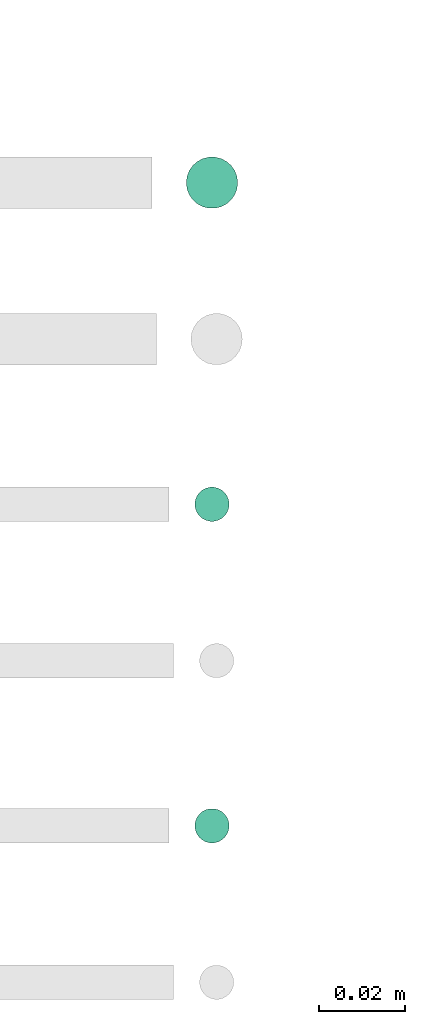
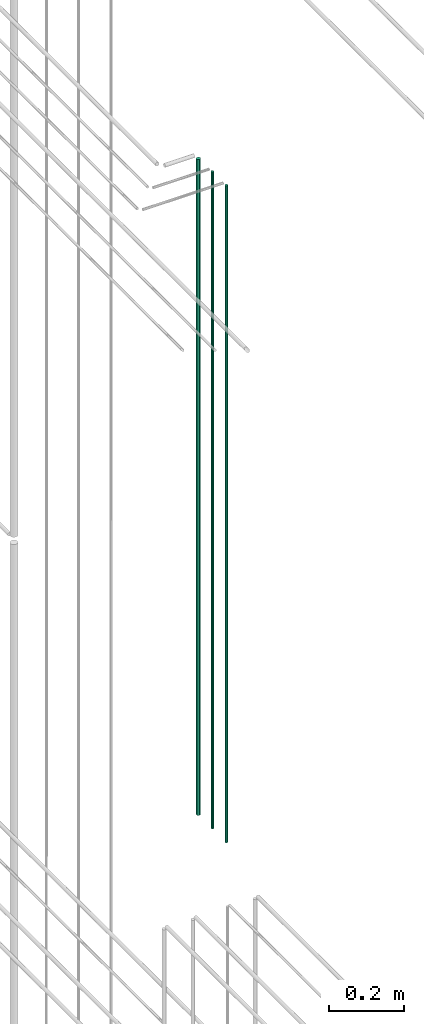
# One storey, part 74 of 331: 3 flow segments.
"""IFC2X3 building model written with IfcOpenShell, lengths in millimetres."""

from ifc_helpers import new_model, entity, si_unit, converted_unit, derived_unit, direction, frame, origin, origin_2d_with_axis, place, context, subcontext, project, spatial, circle, extrude, type_object, element, save


model = new_model("IFC2X3")

# Units and contexts
model_context = context("Model", 3, precision=0.01, world=origin(), true_north=direction((6.12303176911189e-17, 1.0)))
body_context = subcontext(model_context, "Body", "Model", "MODEL_VIEW")
ifc_project = project(units=[si_unit("LENGTHUNIT", "METRE", prefix="MILLI"), si_unit("AREAUNIT", "SQUARE_METRE"), si_unit("VOLUMEUNIT", "CUBIC_METRE"), converted_unit("PLANEANGLEUNIT", "DEGREE", entity("IfcRatioMeasure", 0.0174532925199433), si_unit("PLANEANGLEUNIT", "RADIAN"), dimensions=[0, 0, 0, 0, 0, 0, 0]), si_unit("MASSUNIT", "GRAM", prefix="KILO"), derived_unit("MASSDENSITYUNIT", [(si_unit("MASSUNIT", "GRAM", prefix="KILO"), 1), (si_unit("LENGTHUNIT", "METRE"), -3)]), derived_unit("MOMENTOFINERTIAUNIT", [(si_unit("LENGTHUNIT", "METRE"), 4)]), si_unit("TIMEUNIT", "SECOND"), si_unit("FREQUENCYUNIT", "HERTZ"), si_unit("THERMODYNAMICTEMPERATUREUNIT", "DEGREE_CELSIUS"), derived_unit("THERMALTRANSMITTANCEUNIT", [(si_unit("MASSUNIT", "GRAM", prefix="KILO"), 1), (si_unit("THERMODYNAMICTEMPERATUREUNIT", "KELVIN"), -1), (si_unit("TIMEUNIT", "SECOND"), -3)]), derived_unit("VOLUMETRICFLOWRATEUNIT", [(si_unit("LENGTHUNIT", "METRE"), 3), (si_unit("TIMEUNIT", "SECOND"), -1)]), derived_unit("MASSFLOWRATEUNIT", [(si_unit("MASSUNIT", "GRAM", prefix="KILO"), 1), (si_unit("TIMEUNIT", "SECOND"), -1)]), derived_unit("ROTATIONALFREQUENCYUNIT", [(si_unit("TIMEUNIT", "SECOND"), -1)]), si_unit("ELECTRICCURRENTUNIT", "AMPERE"), si_unit("ELECTRICVOLTAGEUNIT", "VOLT"), si_unit("POWERUNIT", "WATT"), si_unit("FORCEUNIT", "NEWTON", prefix="KILO"), si_unit("ILLUMINANCEUNIT", "LUX"), si_unit("LUMINOUSFLUXUNIT", "LUMEN"), si_unit("LUMINOUSINTENSITYUNIT", "CANDELA"), derived_unit("USERDEFINED", [(si_unit("MASSUNIT", "GRAM", prefix="KILO"), -1), (si_unit("LENGTHUNIT", "METRE"), -2), (si_unit("TIMEUNIT", "SECOND"), 3), (si_unit("LUMINOUSFLUXUNIT", "LUMEN"), 1)]), derived_unit("LINEARVELOCITYUNIT", [(si_unit("LENGTHUNIT", "METRE"), 1), (si_unit("TIMEUNIT", "SECOND"), -1)]), si_unit("PRESSUREUNIT", "PASCAL"), derived_unit("USERDEFINED", [(si_unit("LENGTHUNIT", "METRE"), -2), (si_unit("MASSUNIT", "GRAM", prefix="KILO"), 1), (si_unit("TIMEUNIT", "SECOND"), -2)]), derived_unit("LINEARFORCEUNIT", [(si_unit("MASSUNIT", "GRAM", prefix="KILO"), 1), (si_unit("LENGTHUNIT", "METRE"), 1), (si_unit("TIMEUNIT", "SECOND"), -2), (si_unit("LENGTHUNIT", "METRE"), -1)]), derived_unit("PLANARFORCEUNIT", [(si_unit("MASSUNIT", "GRAM", prefix="KILO"), 1), (si_unit("LENGTHUNIT", "METRE"), 1), (si_unit("TIMEUNIT", "SECOND"), -2), (si_unit("LENGTHUNIT", "METRE"), -2)])], contexts=[model_context])

# Site, building, storey
site_placement = place(None, frame((0.0, -0.00077364408347762, 0.0)))
site = spatial("IfcSite", under=ifc_project, at=site_placement, CompositionType="ELEMENT")
building_placement = place(site_placement, origin())
building = spatial("IfcBuilding", under=site, at=building_placement, CompositionType="ELEMENT")
storey_placement = place(building_placement, origin())
storey = spatial("IfcBuildingStorey", under=building, at=storey_placement, CompositionType="ELEMENT", Elevation=0.0)

# Flow segments
pipe_segment_type = type_object("IfcPipeSegmentType", PredefinedType="NOTDEFINED")
flow_segment_placement = place(storey_placement, frame((62356.8310109464, 3883.89349484373, 16890.0)))
element("IfcFlowSegment", 1, at=flow_segment_placement, inside=storey, type_object=pipe_segment_type, context=body_context, shape_type="SweptSolid", body=[
    extrude(circle(Radius=6.0, at=origin_2d_with_axis()), frame((7.59527223591454, 7.59527223591616, 0.0)), (0.0, 0.0, 1.0), 2146.0),
])
for number, where in (
    (2, (62358.8310109464, 3735.89349484373, 16890.0)),
    (3, (62358.8310109464, 3810.89349484373, 16890.0)),
):
    element("IfcFlowSegment", number, at=place(storey_placement, frame(where)), inside=storey, type_object=pipe_segment_type, context=body_context, shape_type="SweptSolid", body=[
        extrude(circle(Radius=4.0, at=origin_2d_with_axis()), frame((5.59527223591499, 5.59527223591607, 0.0)), (0.0, 0.0, 1.0), 2150.00000000001),
    ])

save(model, "model.ifc")
